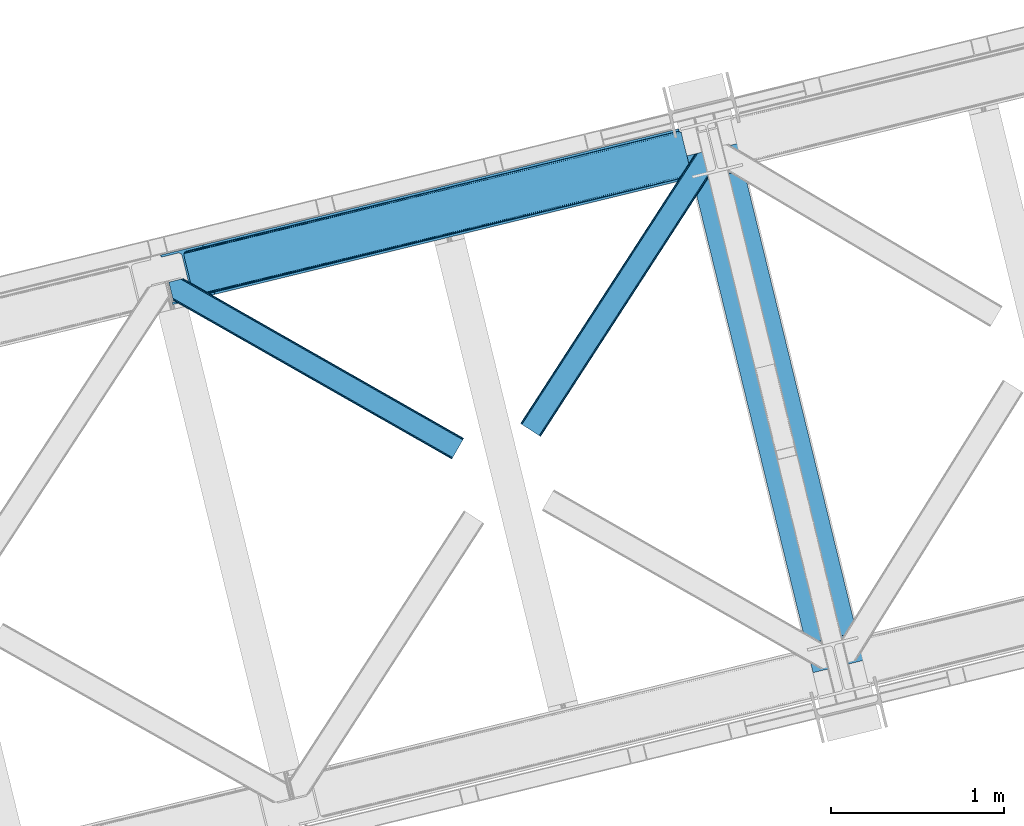
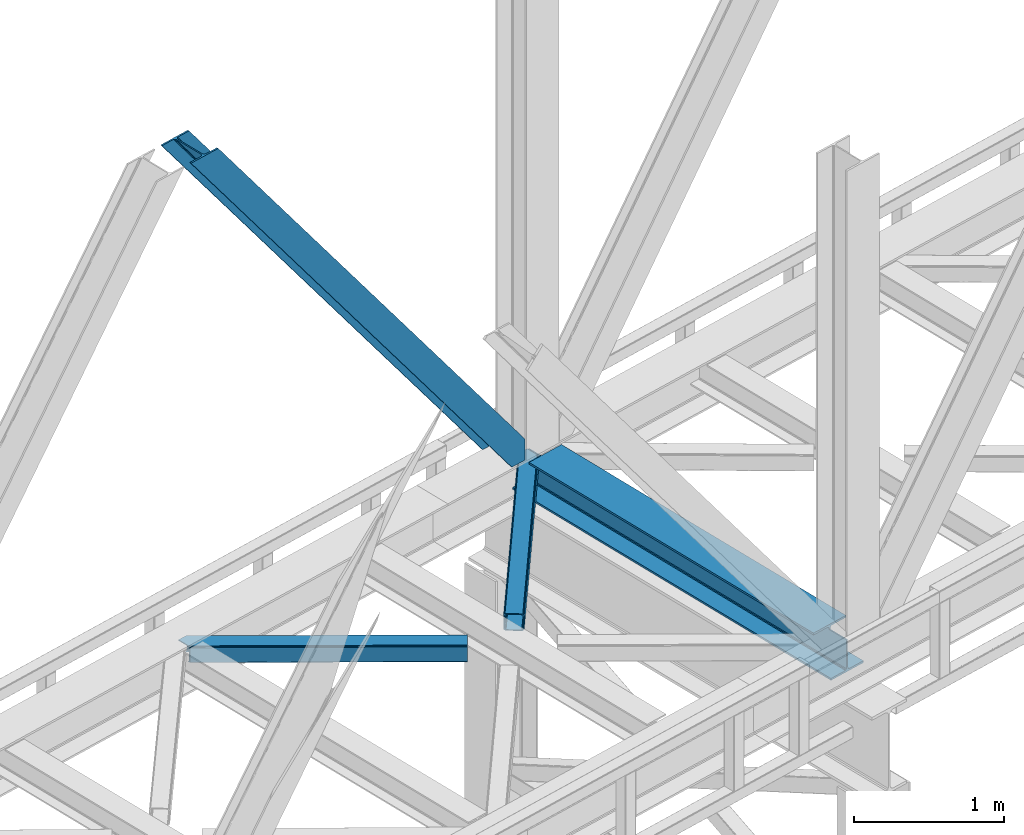
# One storey, part 56 of 92: 3 members, 1 beam.
"""IFC4 building model written with IfcOpenShell, lengths in millimetres."""

from ifc_helpers import new_model, entity, si_unit, converted_unit, derived_unit, direction, frame, origin, place, context, subcontext, project, spatial, triangles, polygons, material, type_object, element, save


model = new_model("IFC4")

# Units and contexts
model_context = context("Model", 3, precision=0.01, world=origin(), true_north=direction((6.12303176911189e-17, 1.0)))
plan_context = context("Plan", 3, precision=0.01, world=origin(), true_north=direction((6.12303176911189e-17, 1.0)))
body_context = subcontext(model_context, "Body", "Model", "MODEL_VIEW")
ifc_project = project(units=[si_unit("LENGTHUNIT", "METRE", prefix="MILLI"), si_unit("AREAUNIT", "SQUARE_METRE"), si_unit("VOLUMEUNIT", "CUBIC_METRE"), converted_unit("PLANEANGLEUNIT", "DEGREE", entity("IfcRatioMeasure", 0.0174532925199433), si_unit("PLANEANGLEUNIT", "RADIAN"), dimensions=[0, 0, 0, 0, 0, 0, 0]), si_unit("MASSUNIT", "GRAM", prefix="KILO"), derived_unit("MASSDENSITYUNIT", [(si_unit("MASSUNIT", "GRAM", prefix="KILO"), 1), (si_unit("LENGTHUNIT", "METRE"), -3)]), derived_unit("MOMENTOFINERTIAUNIT", [(si_unit("LENGTHUNIT", "METRE"), 4)]), si_unit("TIMEUNIT", "SECOND"), si_unit("FREQUENCYUNIT", "HERTZ"), si_unit("THERMODYNAMICTEMPERATUREUNIT", "DEGREE_CELSIUS"), derived_unit("THERMALTRANSMITTANCEUNIT", [(si_unit("MASSUNIT", "GRAM", prefix="KILO"), 1), (si_unit("THERMODYNAMICTEMPERATUREUNIT", "KELVIN"), -1), (si_unit("TIMEUNIT", "SECOND"), -3)]), derived_unit("VOLUMETRICFLOWRATEUNIT", [(si_unit("LENGTHUNIT", "METRE"), 3), (si_unit("TIMEUNIT", "SECOND"), -1)]), derived_unit("MASSFLOWRATEUNIT", [(si_unit("MASSUNIT", "GRAM", prefix="KILO"), 1), (si_unit("TIMEUNIT", "SECOND"), -1)]), derived_unit("ROTATIONALFREQUENCYUNIT", [(si_unit("TIMEUNIT", "SECOND"), -1)]), si_unit("ELECTRICCURRENTUNIT", "AMPERE"), si_unit("ELECTRICVOLTAGEUNIT", "VOLT"), si_unit("POWERUNIT", "WATT"), si_unit("FORCEUNIT", "NEWTON", prefix="KILO"), si_unit("ILLUMINANCEUNIT", "LUX"), si_unit("LUMINOUSFLUXUNIT", "LUMEN"), si_unit("LUMINOUSINTENSITYUNIT", "CANDELA"), derived_unit("USERDEFINED", [(si_unit("MASSUNIT", "GRAM", prefix="KILO"), -1), (si_unit("LENGTHUNIT", "METRE"), -2), (si_unit("TIMEUNIT", "SECOND"), 3), (si_unit("LUMINOUSFLUXUNIT", "LUMEN"), 1)]), derived_unit("LINEARVELOCITYUNIT", [(si_unit("LENGTHUNIT", "METRE"), 1), (si_unit("TIMEUNIT", "SECOND"), -1)]), si_unit("PRESSUREUNIT", "PASCAL"), derived_unit("USERDEFINED", [(si_unit("LENGTHUNIT", "METRE"), -2), (si_unit("MASSUNIT", "GRAM", prefix="KILO"), 1), (si_unit("TIMEUNIT", "SECOND"), -2)]), derived_unit("LINEARFORCEUNIT", [(si_unit("MASSUNIT", "GRAM", prefix="KILO"), 1), (si_unit("LENGTHUNIT", "METRE"), 1), (si_unit("TIMEUNIT", "SECOND"), -2), (si_unit("LENGTHUNIT", "METRE"), -1)]), derived_unit("PLANARFORCEUNIT", [(si_unit("MASSUNIT", "GRAM", prefix="KILO"), 1), (si_unit("LENGTHUNIT", "METRE"), 1), (si_unit("TIMEUNIT", "SECOND"), -2), (si_unit("LENGTHUNIT", "METRE"), -2)])], contexts=[model_context, plan_context])

# Site, building, storey
site_placement = place(None, origin())
site = spatial("IfcSite", under=ifc_project, at=site_placement, CompositionType="ELEMENT")
building_placement = place(site_placement, origin())
building = spatial("IfcBuilding", under=site, at=building_placement, CompositionType="ELEMENT")
storey_placement = place(building_placement, frame((0.0, 0.0, 15900.0)))
storey = spatial("IfcBuildingStorey", under=building, at=storey_placement, Name="05", CompositionType="ELEMENT", Elevation=15900.0)

# Beam
ifc_material = material(Name="Metal painted (White)")
beam_type = type_object("IfcBeamType", PredefinedType="BEAM")
beam_placement = place(storey_placement, frame((-30305.03, 10399.01, 3385.0)))
element("IfcBeam", 1, at=beam_placement, inside=storey, type_object=beam_type, material=ifc_material, ObjectType="Steel Beam", PredefinedType="BEAM", context=body_context, shape_type="Tessellation", body=[
    polygons([(1020.29791862021, 71.0478278971064, 15.4999999999986), (1020.29791862021, 71.0478278971043, 0.0), (291.465617442446, 3060.99928682749, 0.0), (291.465617442446, 3060.99928682749, 15.4999999999986), (896.910807236245, 40.9709140873313, 15.4999999999986), (168.078506058478, 3030.92237301772, 15.4999999999986), (890.218463462283, 39.3395844888286, 16.8701684147963), (161.386162284524, 3029.29104341922, 16.8701684147963), (884.544968361671, 37.9566100336562, 20.7720779386413), (155.712667183908, 3027.90806896404, 20.7720779386413), (880.754060133096, 37.0325360459227, 26.6116982174316), (151.921758955333, 3026.98399497631, 26.6116982174316), (879.4228701897, 36.7080444135051, 33.500000000001), (150.590569011932, 3026.65950334389, 33.500000000001), (140.875048430518, 3024.29124241399, 33.500000000001), (140.875048430518, 3024.29124241399, 259.000000000002), (150.590569011932, 3026.65950334389, 259.000000000002), (-4.33146851719357e-12, 2989.95145893039, 0.0), (4.33146851719357e-12, 2989.95145893039, 15.4999999999986), (123.387111383968, 3020.02837274016, 15.4999999999986), (130.079455157931, 3021.65970233866, 16.8701684147963), (135.752950258555, 3023.04267679384, 20.7720779386413), (139.543858487122, 3023.96675078157, 26.6116982174294), (879.422870189691, 36.7080444135029, 259.000000000002), (869.707349608281, 34.3397834836035, 259.000000000002), (869.707349608281, 34.3397834836035, 33.500000000001), (868.376159664884, 34.0152918511859, 26.6116982174294), (864.585251436314, 33.0912178634524, 20.7720779386413), (858.911756335698, 31.70824340828, 16.8701684147963), (852.219412561735, 30.0769138097752, 15.4999999999986), (728.832301177763, 4.33146851719357e-12, 15.4999999999986), (728.832301177763, 2.16573425859679e-12, 0.0), (839.723099749336, 199.571930111233, 259.069791776412), (188.068298227652, 2872.911390143, 259.000000000002), (188.291691329505, 2871.99494573803, 259.61730333112), (188.304080173131, 2871.94412150426, 266.500003008253), (839.577920935828, 200.167408132524, 266.500002998871), (839.578271056585, 200.16597182779, 260.000004007589), (830.098162468533, 196.83185809429, 259.006343172366), (829.874792453796, 197.748309612736, 259.61730333112), (829.862403610166, 197.799133846509, 266.500003008253), (178.588562847473, 2869.57584721824, 266.500002998871), (178.588212726721, 2869.57728352298, 260.000004007589), (178.443407068381, 2870.17133233677, 259.07612046749), (178.352777646237, 2870.5431292131, 259.000000000002), (840.909408805755, 200.49067757721, 273.388305639783), (844.699685394451, 201.417342749125, 279.227924098781), (850.372756341981, 202.802057212801, 283.129832400615), (857.064948023115, 204.434010743614, 284.500000377228), (980.451976710959, 234.511263798723, 284.500000138971), (980.450306904298, 234.518113867457, 299.999995328161), (688.984884807028, 163.469484603413, 299.999995890962), (688.986554613684, 163.462634534683, 284.500000701776), (812.373583301532, 193.539887589794, 284.500000463519), (819.066070197671, 195.170630056372, 283.129832461069), (824.739981846431, 196.551895700901, 279.227924137322), (828.531516633423, 197.473399350195, 273.388305663684), (177.257074977542, 2869.25257777356, 273.388305639788), (173.46679838885, 2868.32591260164, 279.227924098781), (167.79372744132, 2866.94119813797, 283.129832400619), (161.101535760187, 2865.30924460715, 284.500000377228), (37.7145070723384, 2835.23199155204, 284.500000138971), (37.7161768789945, 2835.22514148331, 299.999995328161), (329.181598976269, 2906.27377074735, 299.999995890962), (329.179929169613, 2906.28062081608, 284.500000701776), (205.792900481765, 2876.20336776097, 284.500000463519), (199.10041358563, 2874.57262529439, 283.129832461065), (193.42650193687, 2873.19135964987, 279.227924137322), (189.634967149874, 2872.26985600057, 273.388305663684)], [[[1, 2, 3, 4]], [[5, 1, 4, 6]], [[7, 5, 6, 8]], [[9, 7, 8, 10]], [[11, 9, 10, 12]], [[13, 11, 12, 14]], [[15, 16, 17, 14, 12, 10, 8, 6, 4, 3, 18, 19, 20, 21, 22, 23]], [[13, 24, 25, 26, 27, 28, 29, 30, 31, 32, 2, 1, 5, 7, 9, 11]], [[2, 32, 18, 3]], [[32, 31, 19, 18]], [[31, 30, 20, 19]], [[27, 26, 15, 23]], [[28, 27, 23, 22]], [[29, 28, 22, 21]], [[30, 29, 21, 20]], [[33, 24, 13, 14, 17, 34, 35, 36, 37, 38]], [[25, 39, 40, 41, 42, 43, 44, 16, 15, 26]], [[39, 25, 24, 33]], [[45, 34, 17, 16]], [[41, 40, 38, 37, 46, 47, 48, 49, 50, 51, 52, 53, 54, 55, 56, 57]], [[42, 58, 59, 60, 61, 62, 63, 64, 65, 66, 67, 68, 69, 36, 35, 43]], [[46, 37, 36, 69]], [[47, 46, 69, 68]], [[48, 47, 68, 67]], [[49, 48, 67, 66]], [[50, 49, 66, 65]], [[51, 50, 65, 64]], [[52, 51, 64, 63]], [[53, 52, 63, 62]], [[54, 53, 62, 61]], [[55, 54, 61, 60]], [[56, 55, 60, 59]], [[57, 56, 59, 58]], [[41, 57, 58, 42]]], closed=False),
])

# Members
member_type_1 = type_object("IfcMemberType", PredefinedType="BRACE")
member_1_placement = place(storey_placement, frame((-33350.06, 12528.13, 3695.0)))
element("IfcMember", 2, at=member_1_placement, inside=storey, type_object=member_type_1, ObjectType="Steel Vertical Brace", PredefinedType="BRACE", context=body_context, shape_type="Tessellation", body=[
    triangles([(3070.87069702148, 756.345693969726, 0.827856445310317), (3071.52647094726, 755.358544921874, 1.13481445312209), (3070.1056274414, 754.873690795897, 0.0), (3068.17783813476, 762.779022216797, 0.0), (3067.78018798828, 753.547027587891, 7.26932373046657), (3067.78018798828, 753.547027587891, 0.0), (3064.92454833984, 750.387918090819, 0.0), (3063.4827758789, 746.380023193358, 0.0), (3065.22220458984, 750.173977661132, 14.9735046386704), (3064.09204101562, 748.682208251952, 18.377947998044), (3063.66881103515, 742.123306274414, 0.0), (3063.35952758789, 744.488278198241, 30.2981506347642), (3063.478125, 743.106967163085, 41.9881347656228), (3063.68508911132, 746.346304321289, 25.0194030761704), (3063.478125, 743.106967163085, 170.743066406249), (3063.66881103515, 742.123306274414, 170.803527832031), (215.791479492182, 48.952825927734, 3911.00081176758), (310.557788085935, 72.0537414550781, 3911.00081176758), (192.89055175781, 54.8071197509762, 3911.00081176758), (199.02971191406, 50.2934417724609, 3911.00081176758), (207.071081542963, 48.2377532958981, 3911.00081176758), (189.588427734372, 61.092782592772, 3911.00081176758), (3066.51049804687, 730.465878295898, 170.803527832031), (313.636669921871, 59.4231170654293, 3911.00081176758), (3066.51049804687, 730.465878295898, 0.0), (2948.45258789062, 701.687402343749, 0.0), (69.8631774902315, 0.0, 3911.00081176758), (2945.37370605468, 714.318026733397, 0.0), (66.7842956542954, 12.630624389647, 3911.00081176758), (161.552929687496, 35.7315399169911, 3911.00081176758), (3040.14001464843, 737.417779541014, 0.0), (3057.81567993164, 760.253594970702, 0.0), (3057.77847290039, 753.154028320312, 0.0), (179.2285949707, 58.5673553466786, 3911.00081176758), (179.191387939449, 51.4677886962891, 3911.00081176758), (3054.4042602539, 746.32188720703, 0.0), (175.817175292963, 44.6356475830071, 3911.00081176758), (3048.21161499023, 740.795480346678, 0.0), (169.622204589839, 39.1092407226552, 3911.00081176758), (3002.63532714843, 986.624661254882, 0.0), (124.048242187499, 284.938421630859, 3911.00081176758), (2976.43227539062, 998.764617919922, 0.0), (2985.15499877929, 999.480853271483, 0.0), (106.5655883789, 297.79461364746, 3911.00081176758), (97.8451904296817, 297.078378295897, 3911.00081176758), (2993.1963684082, 997.42516479492, 0.0), (114.609283447266, 295.738925170897, 3911.00081176758), (2999.33552856445, 992.91032409668, 0.0), (120.748443603516, 291.224084472655, 3911.00081176758), (3.07888183593604, 273.97862548828, 3911.00081176758), (2881.66829223633, 975.664865112303, 0.0), (2878.58941040039, 988.295489501952, 0.0), (0.0, 286.608087158202, 3911.00081176758), (3012.99748535156, 989.151251220703, 0.0), (134.40807495117, 287.463848876952, 3911.00081176758), (144.014465332031, 306.921963500976, 3911.00081176758), (243.773492431639, 346.031204223633, 3911.00081176758), (152.083740234375, 310.29966430664, 3911.00081176758), (137.821820068355, 301.396719360351, 3911.00081176758), (134.447607421869, 294.564578247069, 3911.00081176758), (246.852374267575, 333.400579833984, 3911.00081176758), (2996.64732055664, 1017.07280273437, 170.803527832031), (2996.64732055664, 1017.07280273437, 0.0), (2999.48900756836, 1005.41421203613, 170.803527832031), (2999.77271118164, 1004.45380554199, 170.743066406249), (2999.77271118164, 1004.45380554199, 41.9881347656228), (2999.48900756836, 1005.41421203613, 0.0), (3008.39544067383, 997.164715576171, 0.0), (3001.28192138672, 1001.54933166504, 0.0), (3004.40731201172, 998.655322265624, 0.0), (3011.06969604492, 997.055419921875, 0.0), (3000.30291137695, 1003.17248840332, 30.2981506347642), (3001.44470214843, 1001.67257995605, 25.0194030761704), (3002.88182373047, 999.785485839842, 18.377947998044), (3004.57474365234, 998.982046508789, 14.9735046386704), (3008.39544067383, 997.164715576171, 7.26932373046657), (3012.55565185547, 997.2798248291, 1.13481445312209), (3012.42775268554, 996.101989746094, 0.827856445310317)], [[1, 2, 3], [3, 4, 1], [5, 6, 3], [7, 6, 5], [8, 7, 9], [9, 10, 8], [11, 12, 13], [11, 8, 14], [14, 12, 11], [13, 15, 16], [16, 11, 13], [10, 14, 8], [5, 9, 7], [3, 2, 5], [17, 18, 15], [15, 13, 17], [1, 19, 5], [19, 20, 10], [10, 9, 19], [9, 5, 19], [13, 12, 21], [21, 17, 13], [14, 20, 12], [14, 10, 20], [20, 21, 12], [5, 2, 1], [1, 4, 19], [22, 19, 4], [16, 15, 18], [23, 16, 24], [18, 24, 16], [23, 25, 16], [11, 16, 25], [24, 26, 23], [24, 27, 26], [26, 25, 23], [28, 26, 29], [27, 29, 26], [29, 30, 28], [31, 28, 30], [32, 33, 34], [35, 34, 33], [33, 36, 35], [37, 35, 36], [36, 38, 37], [39, 37, 38], [38, 31, 39], [30, 39, 31], [40, 32, 41], [34, 41, 32], [42, 43, 44], [44, 45, 42], [43, 46, 47], [47, 44, 43], [46, 48, 49], [49, 47, 46], [48, 40, 41], [41, 49, 48], [45, 50, 51], [51, 42, 45], [52, 51, 50], [50, 53, 52], [4, 54, 22], [55, 22, 54], [41, 34, 55], [37, 39, 21], [30, 27, 24], [29, 27, 30], [39, 30, 17], [34, 35, 19], [35, 37, 20], [47, 56, 44], [53, 45, 57], [45, 44, 58], [53, 50, 45], [47, 49, 59], [49, 41, 60], [55, 34, 22], [17, 21, 39], [19, 35, 20], [21, 20, 37], [19, 22, 34], [24, 17, 30], [24, 18, 17], [58, 44, 56], [59, 49, 60], [55, 60, 41], [59, 56, 47], [58, 57, 45], [57, 58, 61], [57, 52, 53], [52, 57, 62], [63, 52, 62], [64, 62, 57], [65, 64, 61], [57, 61, 64], [61, 58, 65], [66, 65, 58], [64, 67, 63], [63, 62, 64], [32, 40, 54], [46, 43, 67], [42, 52, 63], [51, 52, 42], [43, 42, 63], [40, 48, 68], [48, 46, 69], [36, 11, 38], [26, 31, 25], [31, 38, 25], [26, 28, 31], [36, 33, 8], [33, 32, 6], [8, 11, 36], [54, 40, 68], [67, 69, 46], [63, 67, 43], [48, 69, 70], [70, 68, 48], [71, 54, 68], [32, 54, 4], [8, 33, 7], [33, 6, 7], [11, 25, 38], [32, 4, 6], [3, 6, 4], [67, 72, 73], [65, 66, 64], [67, 64, 66], [66, 72, 67], [69, 74, 75], [69, 73, 74], [70, 75, 76], [76, 77, 71], [71, 68, 76], [76, 68, 70], [75, 70, 69], [73, 69, 67], [60, 78, 76], [76, 59, 60], [76, 75, 59], [74, 59, 75], [78, 77, 76], [54, 78, 60], [60, 55, 54], [73, 59, 74], [59, 73, 72], [56, 59, 72], [72, 66, 56], [58, 56, 66], [77, 78, 71], [54, 71, 78]]),
])
member_type_2 = type_object("IfcMemberType", PredefinedType="BRACE")
member_2_placement = place(storey_placement, frame((-31269.04, 11764.69, 3510.58)))
element("IfcMember", 3, at=member_2_placement, inside=storey, type_object=member_type_2, ObjectType="Steel Horizontal Brace", PredefinedType="BRACE", context=body_context, shape_type="Tessellation", body=[
    triangles([(972.968518066409, 1545.29288635254, 0.386022949220205), (1007.16875610352, 1404.99563598633, 0.363931274416245), (14.7014282226592, 66.6447692871097, 0.0), (102.814654541016, 9.54011535644531, 0.0), (1.13248901367479, 75.4349304199222, 10.8028289794929), (0.011627197265625, 76.1581420898438, 17.5000946044929), (1010.67784423828, 1635.6559753418, 17.9070465087898), (968.503674316409, 1566.80901489258, 9.68196716308739), (4.31601562500146, 73.3734283447266, 5.12526855468968), (968.640875244142, 1567.26712646485, 9.92381286621094), (968.357171630862, 1566.32067260742, 9.42384338378906), (968.210668945314, 1565.83116760254, 9.16455688476708), (968.073468017581, 1565.37421875, 8.92387390136719), (968.938531494143, 1561.82676086426, 5.51361694336083), (1012.94282226563, 1636.20826721191, 11.2760559082053), (1013.40325927734, 1636.32105102539, 9.92381286621094), (970.787255859377, 1554.24117736817, 1.71966247558521), (9.07851562500218, 70.2864074707031, 1.33131408691406), (1010.67784423828, 1635.6559753418, 122.907614135744), (0.0, 76.1395385742198, 122.500662231447), (1012.56145019531, 1636.11524963379, 129.604879760744), (1.11853637695458, 75.4140014648438, 129.195602416992), (1017.92856445313, 1637.42330932617, 135.283602905274), (4.29973754883031, 73.3490112304698, 134.874325561523), (1025.96528320313, 1639.38249206543, 139.076394653323), (9.06456298828198, 70.2608276367191, 138.667117309571), (1035.44377441406, 1641.69281616211, 140.411196899415), (14.6828247070334, 66.6191894531257, 139.999594116212), (973.040606689454, 1549.21939086914, 9.92381286621094), (972.796435546876, 1548.6089630127, 9.84707336425708), (972.833642578127, 1547.58344421387, 9.54011535644531), (972.87317504883, 1546.54862365723, 9.23083190917896), (972.912707519532, 1545.5231048584, 8.92387390136719), (1032.56255493164, 1640.99053344727, 9.92381286621094), (14.9525756835938, 66.4773376464855, 8.3320495605476), (20.5754882812507, 62.8368621826176, 6.99957275390625), (975.249774169923, 1535.93996887207, 7.38443298339917), (10.1877502441421, 69.5655212402344, 12.1248413085959), (1027.83726196289, 1639.83827819824, 12.535281372071), (973.075488281251, 1544.85570373535, 8.81574096679833), (1022.46782226563, 1638.53021850586, 18.2116790771506), (1020.58421630859, 1638.07094421387, 24.9089447021506), (7.00422363281541, 71.6270233154301, 17.8024017333992), (5.88568725586083, 72.3502349853516, 24.4996673583992), (1004.8875, 1414.3485534668, 7.36582946777344), (96.9382690429702, 13.3456970214847, 6.99957275390625), (1007.06178588867, 1405.4363067627, 8.80411376953271), (1007.24084472656, 1404.70030517578, 8.92387390136719), (1012.06845703125, 1384.89221191406, 8.92387390136719), (1011.19874267578, 1388.46176147461, 5.48687438964771), (1009.35001831055, 1396.0473449707, 1.69524536133031), (1020.58421630859, 1638.07094421387, 115.908041381837), (5.87638549804979, 72.3339569091804, 115.498764038086), (1035.87398071289, 1641.7974609375, 132.079147338867), (1045.34782104492, 1644.10778503418, 133.411624145509), (20.5592102050796, 62.8124450683608, 133.000021362306), (14.9386230468772, 66.4552459716797, 131.667544555665), (1027.83726196289, 1639.83827819824, 128.284030151368), (10.1737976074219, 69.5434295654304, 127.874752807616), (1022.46782226563, 1638.53021850586, 122.605307006837), (6.99259643554979, 71.6084197998061, 122.196029663086), (1095.16803588867, 1656.2512298584, 140.420498657226), (1095.16803588867, 1656.2512298584, 133.42092590332), (1115.62260131836, 1572.34239807129, 140.40887145996), (102.798376464845, 9.5145355224613, 139.999594116212), (1113.34134521485, 1581.69647827149, 133.409298706054), (96.92431640625, 13.3224426269535, 133.000021362306), (1117.80153808594, 1563.39526977539, 139.074069213868), (108.418963623048, 5.87289733886792, 138.667117309571), (1119.65258789063, 1555.80852355957, 135.278952026369), (113.181463623048, 2.78587646484448, 134.874325561523), (1120.88739624024, 1550.74022827148, 129.602554321289), (116.36731567383, 0.72321166992333, 129.195602416992), (1121.32225341797, 1548.96010437012, 122.905288696289), (117.485852050784, 0.0, 122.500662231447), (1121.32225341797, 1548.96010437012, 17.9047210693352), (117.499804687501, 0.0197662353530177, 17.5000946044929), (107.309729003908, 6.59378356933667, 127.874752807616), (110.495581054689, 4.53228149414099, 122.196029663086), (111.611791992189, 3.80790710449219, 115.498764038086), (102.544903564456, 9.6808044433601, 131.667544555665), (116.38126831055, 0.74530334472729, 10.8028289794929), (107.323681640628, 6.61471252441515, 12.1248413085959), (113.197741699219, 2.80913085937573, 5.12526855468968), (111.623419189455, 3.82534790039063, 24.4996673583992), (110.507208251955, 4.55088500976672, 17.8024017333992), (108.432916259768, 5.89731445312646, 1.33131408691406), (102.558856201173, 9.70289611816406, 8.3320495605476), (1118.60846557617, 1560.09314575195, 122.602981567383), (1119.04099731446, 1558.31302185059, 115.905715942383), (1117.37133178711, 1565.16260375977, 128.281704711913), (1115.52260742188, 1572.74818725586, 132.076821899416), (1119.04099731446, 1558.31302185059, 24.9054565429688), (1118.60846557617, 1560.09314575195, 18.209353637696), (1120.69438476563, 1551.53436584473, 9.92381286621094), (1117.37133178711, 1565.16260375977, 12.5329559326165), (1120.79902954102, 1551.09834594727, 11.2725677490234), (1116.2853515625, 1569.61698303223, 9.92381286621094), (1012.19868164063, 1384.68524780274, 9.30640869140552), (1012.7358581543, 1385.10731506348, 9.72266235351708), (1012.99630737305, 1385.31079101563, 9.92381286621094), (1008.6035522461, 1403.32829589844, 9.92381286621094), (1007.57570800781, 1403.93872375488, 9.27734069824146)], [[1, 2, 3], [4, 3, 2], [5, 6, 7], [8, 9, 10], [9, 8, 11], [12, 9, 11], [9, 12, 13], [13, 14, 9], [5, 15, 10], [10, 9, 5], [15, 16, 10], [17, 1, 18], [3, 18, 1], [14, 17, 9], [18, 9, 17], [7, 15, 5], [19, 7, 20], [6, 20, 7], [21, 19, 22], [20, 22, 19], [23, 21, 24], [22, 24, 21], [25, 23, 26], [24, 26, 23], [27, 25, 28], [26, 28, 25], [8, 10, 29], [11, 8, 30], [12, 11, 31], [13, 12, 32], [32, 33, 13], [31, 32, 12], [30, 31, 11], [29, 30, 8], [16, 34, 29], [29, 10, 16], [35, 36, 37], [38, 30, 29], [29, 39, 38], [29, 34, 39], [38, 35, 40], [40, 33, 38], [31, 38, 32], [31, 30, 38], [38, 33, 32], [37, 40, 35], [41, 42, 43], [44, 43, 42], [39, 41, 38], [43, 38, 41], [45, 37, 36], [36, 46, 45], [1, 37, 45], [13, 33, 14], [33, 40, 1], [37, 1, 40], [33, 17, 14], [33, 1, 17], [2, 1, 45], [2, 45, 47], [48, 2, 47], [49, 50, 48], [48, 51, 2], [48, 50, 51], [42, 52, 53], [53, 44, 42], [54, 55, 56], [56, 57, 54], [58, 54, 57], [57, 59, 58], [60, 58, 59], [59, 61, 60], [52, 60, 61], [61, 53, 52], [60, 19, 21], [54, 25, 27], [62, 55, 27], [55, 62, 63], [55, 54, 27], [58, 25, 54], [58, 60, 23], [23, 25, 58], [21, 23, 60], [42, 7, 19], [39, 16, 41], [60, 52, 19], [39, 34, 16], [42, 41, 7], [52, 42, 19], [15, 7, 41], [41, 16, 15], [64, 27, 28], [27, 64, 62], [28, 65, 64], [55, 66, 56], [55, 63, 66], [67, 56, 66], [68, 64, 65], [65, 69, 68], [70, 68, 69], [69, 71, 70], [72, 70, 71], [71, 73, 72], [74, 72, 73], [73, 75, 74], [76, 74, 75], [75, 77, 76], [73, 78, 79], [80, 77, 75], [73, 79, 75], [73, 71, 78], [79, 80, 75], [78, 71, 69], [67, 65, 28], [65, 81, 69], [81, 65, 67], [81, 78, 69], [82, 83, 84], [85, 77, 80], [77, 86, 82], [86, 77, 85], [82, 86, 83], [4, 46, 3], [87, 84, 83], [83, 88, 87], [88, 46, 4], [4, 87, 88], [59, 26, 24], [28, 56, 67], [28, 57, 56], [57, 28, 26], [59, 57, 26], [53, 20, 6], [22, 61, 59], [24, 22, 59], [61, 22, 20], [53, 61, 20], [18, 38, 9], [3, 46, 36], [36, 35, 3], [35, 38, 18], [18, 3, 35], [5, 9, 38], [6, 44, 53], [43, 6, 5], [6, 43, 44], [43, 5, 38], [89, 90, 79], [80, 79, 90], [91, 89, 78], [79, 78, 89], [92, 91, 81], [78, 81, 91], [66, 92, 67], [81, 67, 92], [90, 93, 80], [85, 80, 93], [94, 95, 96], [93, 74, 76], [76, 97, 94], [97, 95, 94], [94, 93, 76], [90, 74, 93], [89, 91, 70], [72, 89, 70], [72, 74, 89], [90, 89, 74], [91, 68, 70], [92, 68, 91], [98, 96, 95], [92, 66, 64], [92, 64, 68], [66, 62, 64], [66, 63, 62], [82, 97, 76], [82, 99, 100], [101, 97, 82], [101, 95, 97], [84, 50, 99], [99, 82, 84], [51, 50, 87], [84, 87, 50], [2, 51, 4], [87, 4, 51], [76, 77, 82], [102, 103, 88], [48, 88, 103], [83, 96, 102], [102, 88, 83], [96, 98, 102], [46, 88, 48], [48, 45, 46], [94, 96, 83], [83, 86, 94], [93, 94, 86], [86, 85, 93], [99, 48, 103], [99, 103, 102], [98, 95, 102], [101, 102, 95]]),
])
member_type_3 = type_object("IfcMemberType", PredefinedType="BRACE")
member_3_placement = place(storey_placement, frame((-33302.32, 11633.94, 3510.58)))
element("IfcMember", 4, at=member_3_placement, inside=storey, type_object=member_type_3, ObjectType="Steel Horizontal Brace", PredefinedType="BRACE", context=body_context, shape_type="Tessellation", body=[
    triangles([(1706.21445922852, 121.662341308593, 122.500662231447), (1706.19353027344, 121.673968505858, 17.5000946044929), (84.490191650395, 1045.00249328613, 17.9093719482444), (84.490191650395, 1045.00249328613, 122.909939575195), (1697.55917358398, 106.45280456543, 139.999594116212), (1700.87059936524, 112.2733795166, 138.667117309571), (69.2027526855454, 1041.2759765625, 139.078720092773), (59.7242614746137, 1038.96565246582, 140.413522338869), (1703.67973022461, 117.206799316406, 134.874325561523), (77.2371459960923, 1043.23399658203, 135.285928344729), (1705.55635986328, 120.504272460938, 129.197927856447), (82.6065856933637, 1044.54321899414, 129.607205200195), (20.454565429689, 940.498406982422, 140.411196899415), (1645.60653076172, 15.2060485839847, 139.999594116212), (0.0, 1024.40723876953, 140.42282409668), (1636.94426879883, 0.0, 122.500662231447), (1637.60701904297, 1.15806884765516, 129.197927856447), (26.1542175292998, 917.11611328125, 122.907614135744), (25.7193603515625, 918.896237182616, 129.604879760744), (1639.48364868164, 4.45321655273438, 134.874325561523), (24.4845520019517, 923.964532470703, 135.28127746582), (1642.29277954102, 9.38663635253943, 138.667117309571), (22.6358276367173, 931.551278686524, 139.076394653323), (1636.9256652832, 0.011627197265625, 17.5000946044929), (26.1542175292998, 917.11611328125, 17.9070465087898), (1705.5354309082, 120.517062377929, 10.8028289794929), (82.2252136230454, 1044.45020141602, 11.2783813476563), (153.281341552734, 1003.62943725586, 9.92613830566552), (1703.65647583008, 117.220751953124, 5.12643127441333), (155.520739746098, 998.663461303711, 5.51594238281177), (154.658001708987, 1002.20975646973, 8.92619934082177), (81.762451171875, 1044.33858032226, 9.92613830566552), (1700.84734497071, 112.288494873046, 1.33247680664135), (157.37178955078, 991.076715087891, 1.72198791503979), (1697.53359375, 106.467919921875, 0.0), (159.553051757815, 982.128424072265, 0.388348388671147), (1645.58095092774, 15.2211639404286, 0.0), (193.750964355473, 841.831173706054, 0.366256713867188), (157.68107299805, 985.581701660156, 9.92613830566552), (62.6054809570342, 1039.66793518066, 9.92613830566552), (159.657696533206, 981.692404174804, 8.81806640624927), (159.143774414064, 983.47601623535, 9.3087341308601), (158.657757568362, 984.173648071288, 9.51337280273583), (153.613879394536, 1003.28643493652, 9.68429260253833), (158.167089843751, 984.882907104491, 9.7203369140625), (1697.384765625, 106.203982543944, 8.3320495605476), (1700.19389648438, 111.137402343749, 12.1260040283196), (67.3307739257798, 1040.82019042969, 12.5376068115256), (161.831982421878, 972.775506591797, 7.38675842285375), (1694.0710144043, 100.384570312499, 7.00073547363354), (1702.0728515625, 114.433712768554, 17.8035644531265), (72.7002136230512, 1042.12825012207, 18.2140045166016), (1702.73095092774, 115.590618896484, 24.5008300781265), (74.5838195800825, 1042.58752441406, 24.9112701416016), (1702.74955444336, 115.580154418945, 115.501089477541), (74.5838195800825, 1042.58752441406, 115.910366821288), (67.3307739257798, 1040.82019042969, 128.286355590823), (59.2940551757856, 1038.86100769043, 132.081472778322), (72.7002136230512, 1042.12825012207, 122.607632446288), (49.8202148437485, 1036.55184631348, 133.416275024414), (0.0, 1024.40723876953, 133.423251342774), (1702.09378051758, 114.422085571288, 122.198355102541), (1700.21482543946, 111.124612426758, 127.874752807616), (1697.40802001953, 106.190029907226, 131.667544555665), (1694.09426879883, 100.370617675781, 133.000021362306), (18.1733093261719, 949.852487182618, 133.411624145509), (1649.07143554688, 21.2905609130848, 133.000021362306), (1649.04585571289, 21.3033508300778, 7.00073547363354), (191.472033691411, 851.184091186524, 7.36815490722802), (1642.94622802734, 10.5377288818363, 127.874752807616), (1645.75535888672, 15.4699859619141, 131.667544555665), (1640.40684814453, 6.08451232910193, 115.501089477541), (1641.06727294922, 7.24141845703161, 122.198355102541), (1642.26719970703, 9.40175170898328, 1.33247680664135), (1642.92297363281, 10.5493560791019, 12.1260040283196), (1639.45806884766, 4.46716918945276, 5.12643127441333), (1645.73210449219, 15.4839385986324, 8.3320495605476), (1637.58376464844, 1.17085876464807, 10.8028289794929), (1640.39057006836, 6.09381408691297, 24.5008300781265), (1641.0486694336, 7.25304565429724, 17.8035644531265), (20.3545715332075, 940.904196166992, 132.079147338867), (22.2032958984419, 933.318612670899, 128.284030151368), (23.4404296875, 928.249154663086, 122.605307006837), (23.8729614257827, 926.469030761718, 115.908041381837), (23.8729614257827, 926.469030761718, 24.9077819824233), (23.4404296875, 928.249154663086, 18.2116790771506), (22.2032958984419, 933.318612670899, 12.535281372071), (25.526348876956, 919.690374755859, 9.92613830566552), (25.6333190918012, 919.254354858398, 11.274893188478), (21.1173156738296, 937.772991943359, 9.92613830566552), (195.932226562501, 832.88288269043, 1.69757080078125), (193.643994140628, 842.271844482422, 8.80643920898365), (197.780950927736, 825.297299194335, 5.48919982910229), (198.650665283203, 821.727749633788, 8.92619934082177), (197.636773681639, 821.67310180664, 9.92613830566552), (193.244018554688, 839.690606689453, 9.92613830566552)], [[1, 2, 3], [3, 4, 1], [5, 6, 7], [7, 8, 5], [6, 9, 10], [10, 7, 6], [9, 11, 12], [12, 10, 9], [11, 1, 4], [4, 12, 11], [5, 13, 14], [13, 5, 8], [15, 13, 8], [16, 17, 18], [19, 18, 17], [17, 20, 19], [21, 19, 20], [20, 22, 21], [23, 21, 22], [22, 14, 23], [13, 23, 14], [24, 16, 25], [18, 25, 16], [26, 27, 3], [27, 26, 28], [26, 29, 30], [30, 31, 26], [31, 28, 26], [28, 32, 27], [29, 33, 34], [34, 30, 29], [33, 35, 36], [36, 34, 33], [3, 2, 26], [35, 37, 38], [38, 36, 35], [28, 39, 32], [40, 32, 39], [31, 41, 42], [31, 42, 43], [44, 43, 45], [44, 45, 39], [46, 42, 41], [43, 46, 45], [43, 42, 46], [39, 45, 46], [47, 48, 39], [39, 46, 47], [48, 40, 39], [46, 41, 49], [49, 50, 46], [47, 51, 52], [52, 48, 47], [51, 53, 54], [54, 52, 51], [53, 55, 54], [56, 54, 55], [57, 58, 7], [10, 57, 7], [10, 12, 59], [57, 10, 59], [59, 12, 4], [58, 8, 7], [15, 60, 61], [15, 8, 60], [58, 60, 8], [59, 4, 56], [54, 3, 52], [4, 54, 56], [3, 27, 52], [4, 3, 54], [32, 52, 27], [48, 52, 32], [40, 48, 32], [55, 62, 56], [59, 56, 62], [62, 63, 59], [57, 59, 63], [63, 64, 57], [58, 57, 64], [64, 65, 58], [60, 58, 65], [65, 66, 60], [65, 67, 66], [66, 61, 60], [68, 50, 69], [49, 69, 50], [11, 63, 62], [55, 2, 1], [11, 62, 1], [11, 9, 63], [62, 55, 1], [63, 9, 6], [65, 5, 14], [5, 64, 6], [64, 5, 65], [64, 63, 6], [26, 47, 29], [53, 2, 55], [2, 51, 26], [51, 2, 53], [26, 51, 47], [35, 50, 37], [33, 29, 47], [47, 46, 33], [46, 50, 35], [35, 33, 46], [70, 22, 20], [14, 67, 65], [14, 71, 67], [71, 14, 22], [70, 71, 22], [72, 16, 24], [17, 73, 70], [20, 17, 70], [73, 17, 16], [72, 73, 16], [74, 75, 76], [37, 50, 68], [68, 77, 37], [77, 75, 74], [74, 37, 77], [78, 76, 75], [24, 79, 72], [80, 24, 78], [24, 80, 79], [80, 78, 75], [67, 71, 81], [81, 66, 67], [71, 70, 82], [82, 81, 71], [70, 73, 83], [83, 82, 70], [73, 72, 84], [84, 83, 73], [72, 79, 85], [85, 84, 72], [83, 21, 82], [84, 85, 18], [19, 83, 18], [83, 19, 21], [83, 84, 18], [85, 25, 18], [86, 87, 88], [88, 89, 86], [89, 25, 86], [85, 86, 25], [66, 13, 15], [13, 81, 23], [81, 13, 66], [15, 61, 66], [81, 82, 23], [90, 88, 87], [23, 82, 21], [49, 36, 69], [34, 41, 30], [41, 34, 36], [30, 41, 31], [36, 49, 41], [69, 36, 38], [91, 92, 38], [92, 91, 93], [38, 92, 69], [93, 94, 92], [78, 24, 25], [76, 95, 94], [94, 93, 76], [78, 89, 95], [95, 76, 78], [89, 88, 95], [37, 74, 91], [91, 38, 37], [74, 76, 93], [93, 91, 74], [25, 89, 78], [68, 69, 92], [96, 87, 75], [96, 90, 87], [92, 75, 77], [92, 96, 75], [92, 77, 68], [79, 80, 85], [86, 85, 80], [80, 75, 86], [87, 86, 75], [96, 95, 88], [88, 90, 96]]),
])

save(model, "model.ifc")
